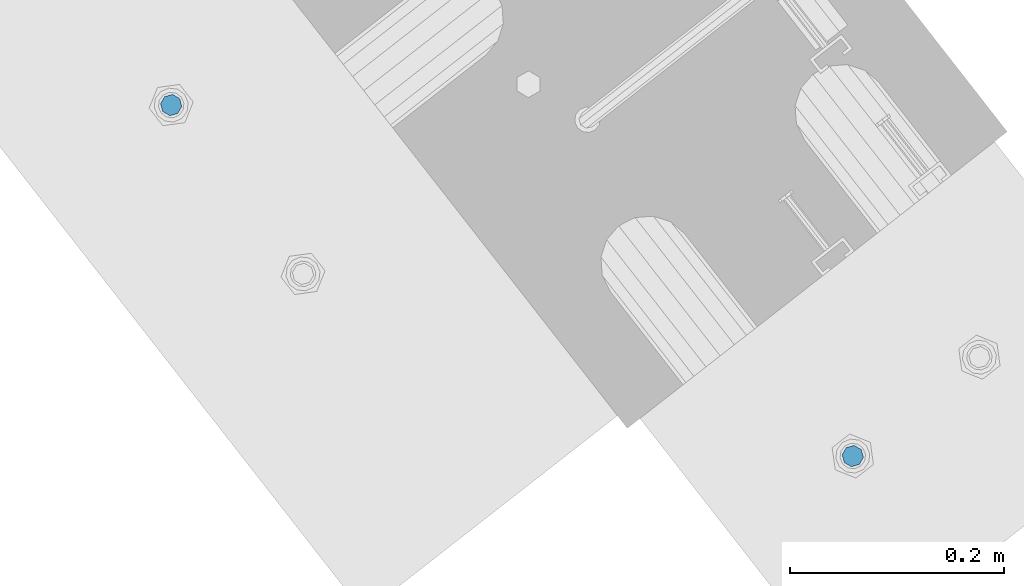
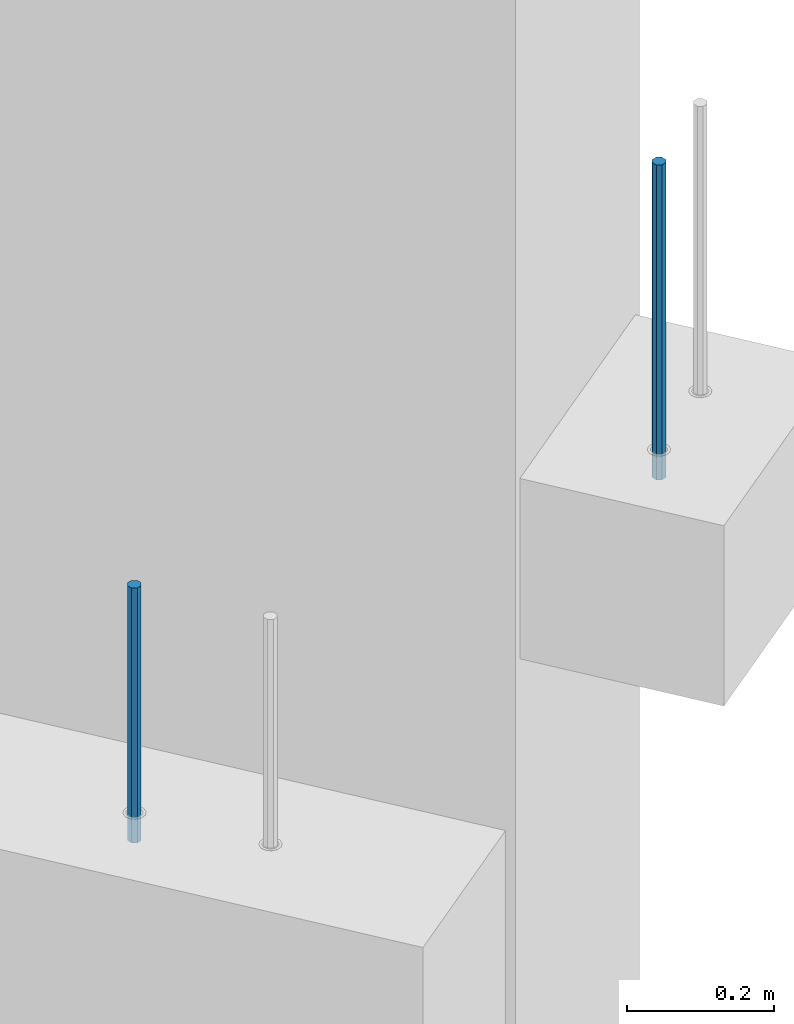
# One storey, part 16 of 42: 2 beams, 1 element without a shape of its own.
"""IFC2X3 building model written with IfcOpenShell, lengths in millimetres."""

from ifc_helpers import new_model, si_unit, frame, origin_with_axes, place, context, subcontext, project, spatial, faceted_brep, material, type_object, element, aggregate, save


model = new_model("IFC2X3")

# Units and contexts
model_context = context("Model", 3, precision=1e-05, world=origin_with_axes())
body_context = subcontext(model_context, "Body", "Model", "MODEL_VIEW")
ifc_project = project(units=[si_unit("LENGTHUNIT", "METRE", prefix="MILLI"), si_unit("AREAUNIT", "SQUARE_METRE"), si_unit("VOLUMEUNIT", "CUBIC_METRE"), si_unit("MASSUNIT", "GRAM", prefix="KILO"), si_unit("TIMEUNIT", "SECOND"), si_unit("PLANEANGLEUNIT", "RADIAN"), si_unit("SOLIDANGLEUNIT", "STERADIAN"), si_unit("THERMODYNAMICTEMPERATUREUNIT", "DEGREE_CELSIUS"), si_unit("LUMINOUSINTENSITYUNIT", "LUMEN")], contexts=[model_context])

# Site, building, storey
site_placement = place(None, frame((171687.4, 84828.52, 14700.0), z_axis=(0.0, 0.0, 1.0), x_axis=(1.0, 0.0, 0.0)))
site = spatial("IfcSite", under=ifc_project, at=site_placement, CompositionType="ELEMENT")
building_placement = place(site_placement, origin_with_axes())
building = spatial("IfcBuilding", under=site, at=building_placement, Name="Undefined", CompositionType="ELEMENT")
storey_placement = place(building_placement, origin_with_axes())
storey = spatial("IfcBuildingStorey", under=building, at=storey_placement, Name="Undefined", CompositionType="ELEMENT", Elevation=0.0)

# Assembly, beams
assembly_placement = place(storey_placement, origin_with_axes())
assembly = element("IfcElementAssembly", 1, at=assembly_placement, inside=storey, AssemblyPlace="NOTDEFINED", PredefinedType="REINFORCEMENT_UNIT")
ifc_material = material(Name="STEEL/S235JR")
beam_type = type_object("IfcBeamType", PredefinedType="NOTDEFINED")
beam_1_placement = place(assembly_placement, frame((17739.6624293569, 265197.341079639, 5549.99999999999), z_axis=(-0.788225611989142, -0.615386370180835, 0.0), x_axis=(0.0, 0.0, -1.0)))
beam_1 = element("IfcBeam", 2, at=beam_1_placement, type_object=beam_type, material=ifc_material, context=body_context, shape_type="Brep", body=[
    faceted_brep([(4.88085788674653e-07, -10.0, -3.86498868465424e-08), (0.0, -7.07106819456385, -7.07106766643119), (424.0, -7.07106751357787, -7.07106759684393), (424.0, -9.99999970174395, 2.15019099414349e-07), (4.97872867461239e-11, -3.88578058618805e-15, -10.0), (424.0, 2.98285158351064e-07, -9.9999997849518), (0.0, 7.07106742914766, -7.0710676664894), (424.0, 7.07106811014819, -7.07106759675662), (4.88085788674653e-07, 10.0, -3.86498868465424e-08), (424.0, 10.0000002982561, 2.15106410905719e-07), (0.0, 7.07106742919132, 7.07106795720756), (424.0, 7.07106811011909, 7.07106802696944), (-4.97872867461239e-11, 0.0, 10.0), (424.0, 2.98256054520607e-07, 10.0000002150773), (0.0, -7.07106819453475, 7.07106795729487), (424.0, -7.07106751357787, 7.07106802688213)], [[[0, 1, 2, 3]], [[1, 4, 5, 2]], [[4, 6, 7, 5]], [[6, 8, 9, 7]], [[8, 10, 11, 9]], [[10, 12, 13, 11]], [[12, 14, 15, 13]], [[14, 0, 3, 15]], [[5, 7, 9, 11, 13, 15, 3, 2]], [[14, 12, 10, 8, 6, 4, 1, 0]]]),
])
beam_2_placement = place(assembly_placement, frame((18376.1312535663, 264869.610342897, 6229.99999999999), z_axis=(0.615386370178831, -0.788225611990706, 0.0), x_axis=(0.0, 0.0, -1.0)))
beam_2 = element("IfcBeam", 3, at=beam_2_placement, type_object=beam_type, material=ifc_material, context=body_context, shape_type="Brep", body=[
    faceted_brep([(4.88085788674653e-07, -10.0, -3.86498868465424e-08), (0.0, -7.07106819456385, -7.07106766643119), (524.0, -7.07106759562157, -7.07106811032281), (524.0, -9.99999978375854, -2.98430677503347e-07), (4.97872867461239e-11, -3.88578058618805e-15, -10.0), (524.0, 2.16212356463075e-07, -10.000000298518), (0.0, 7.07106742914766, -7.0710676664894), (524.0, 7.07106802810449, -7.07106811041012), (4.88085788674653e-07, 10.0, -3.86498868465424e-08), (524.0, 10.0000002162415, -2.98547092825174e-07), (0.0, 7.07106742919132, 7.07106795720756), (524.0, 7.0710680281336, 7.07106751331594), (-4.97872867461239e-11, 0.0, 10.0), (524.0, 2.16299667954445e-07, 9.99999970148201), (0.0, -7.07106819453475, 7.07106795729487), (524.0, -7.07106759559247, 7.07106751340325)], [[[0, 1, 2, 3]], [[1, 4, 5, 2]], [[4, 6, 7, 5]], [[6, 8, 9, 7]], [[8, 10, 11, 9]], [[10, 12, 13, 11]], [[12, 14, 15, 13]], [[14, 0, 3, 15]], [[5, 7, 9, 11, 13, 15, 3, 2]], [[14, 12, 10, 8, 6, 4, 1, 0]]]),
])
aggregate(assembly, [beam_1, beam_2])

save(model, "model.ifc")
